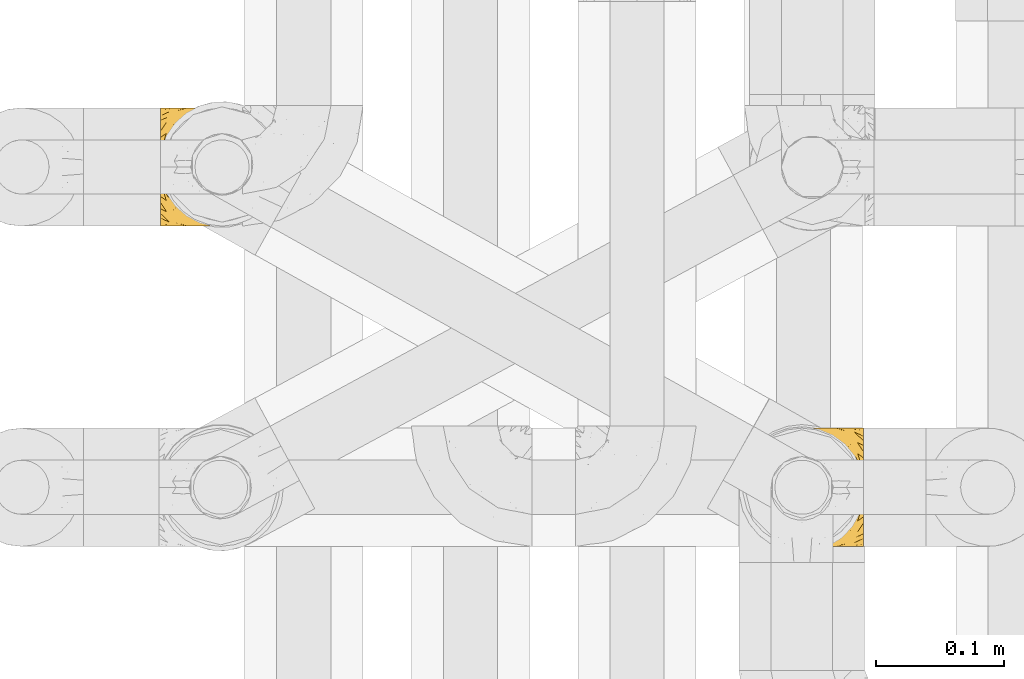
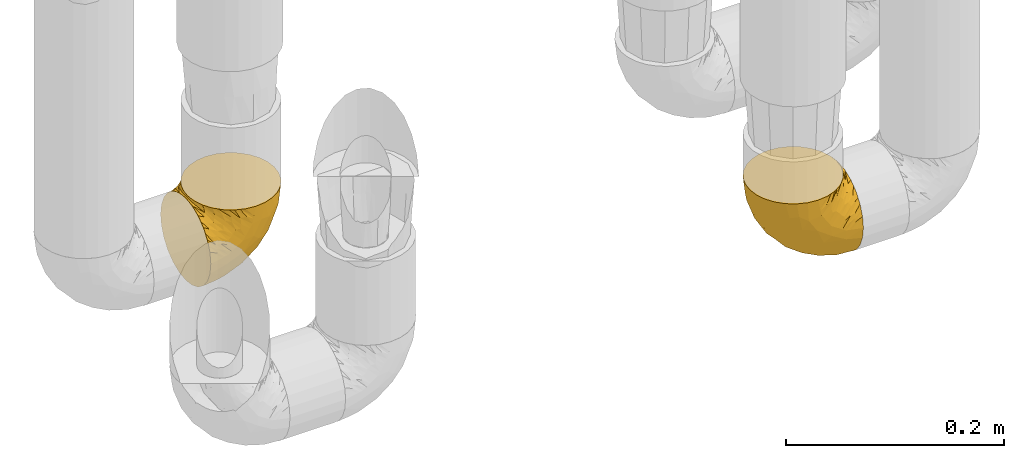
# One storey, part 162 of 827: 2 coverings.
"""IFC2X3 building model written with IfcOpenShell, lengths in millimetres."""

from ifc_helpers import new_model, entity, si_unit, converted_unit, derived_unit, direction, frame, origin, place, context, subcontext, project, spatial, faceted_brep, element, save


model = new_model("IFC2X3")

# Units and contexts
model_context = context("Model", 3, precision=0.01, world=origin(), true_north=direction((6.12303176911189e-17, 1.0)))
body_context = subcontext(model_context, "Body", "Model", "MODEL_VIEW")
ifc_project = project(units=[si_unit("LENGTHUNIT", "METRE", prefix="MILLI"), si_unit("AREAUNIT", "SQUARE_METRE"), si_unit("VOLUMEUNIT", "CUBIC_METRE"), converted_unit("PLANEANGLEUNIT", "DEGREE", entity("IfcRatioMeasure", 0.0174532925199433), si_unit("PLANEANGLEUNIT", "RADIAN"), dimensions=[0, 0, 0, 0, 0, 0, 0]), si_unit("MASSUNIT", "GRAM", prefix="KILO"), derived_unit("MASSDENSITYUNIT", [(si_unit("MASSUNIT", "GRAM", prefix="KILO"), 1), (si_unit("LENGTHUNIT", "METRE"), -3)]), derived_unit("MOMENTOFINERTIAUNIT", [(si_unit("LENGTHUNIT", "METRE"), 4)]), si_unit("TIMEUNIT", "SECOND"), si_unit("FREQUENCYUNIT", "HERTZ"), si_unit("THERMODYNAMICTEMPERATUREUNIT", "DEGREE_CELSIUS"), derived_unit("THERMALTRANSMITTANCEUNIT", [(si_unit("MASSUNIT", "GRAM", prefix="KILO"), 1), (si_unit("THERMODYNAMICTEMPERATUREUNIT", "KELVIN"), -1), (si_unit("TIMEUNIT", "SECOND"), -3)]), derived_unit("VOLUMETRICFLOWRATEUNIT", [(si_unit("LENGTHUNIT", "METRE"), 3), (si_unit("TIMEUNIT", "SECOND"), -1)]), derived_unit("MASSFLOWRATEUNIT", [(si_unit("MASSUNIT", "GRAM", prefix="KILO"), 1), (si_unit("TIMEUNIT", "SECOND"), -1)]), derived_unit("ROTATIONALFREQUENCYUNIT", [(si_unit("TIMEUNIT", "SECOND"), -1)]), si_unit("ELECTRICCURRENTUNIT", "AMPERE"), si_unit("ELECTRICVOLTAGEUNIT", "VOLT"), si_unit("POWERUNIT", "WATT"), si_unit("FORCEUNIT", "NEWTON", prefix="KILO"), si_unit("ILLUMINANCEUNIT", "LUX"), si_unit("LUMINOUSFLUXUNIT", "LUMEN"), si_unit("LUMINOUSINTENSITYUNIT", "CANDELA"), derived_unit("USERDEFINED", [(si_unit("MASSUNIT", "GRAM", prefix="KILO"), -1), (si_unit("LENGTHUNIT", "METRE"), -2), (si_unit("TIMEUNIT", "SECOND"), 3), (si_unit("LUMINOUSFLUXUNIT", "LUMEN"), 1)]), derived_unit("LINEARVELOCITYUNIT", [(si_unit("LENGTHUNIT", "METRE"), 1), (si_unit("TIMEUNIT", "SECOND"), -1)]), si_unit("PRESSUREUNIT", "PASCAL"), derived_unit("USERDEFINED", [(si_unit("LENGTHUNIT", "METRE"), -2), (si_unit("MASSUNIT", "GRAM", prefix="KILO"), 1), (si_unit("TIMEUNIT", "SECOND"), -2)]), derived_unit("LINEARFORCEUNIT", [(si_unit("MASSUNIT", "GRAM", prefix="KILO"), 1), (si_unit("LENGTHUNIT", "METRE"), 1), (si_unit("TIMEUNIT", "SECOND"), -2), (si_unit("LENGTHUNIT", "METRE"), -1)]), derived_unit("PLANARFORCEUNIT", [(si_unit("MASSUNIT", "GRAM", prefix="KILO"), 1), (si_unit("LENGTHUNIT", "METRE"), 1), (si_unit("TIMEUNIT", "SECOND"), -2), (si_unit("LENGTHUNIT", "METRE"), -2)])], contexts=[model_context])

# Site, building, storey
site_placement = place(None, origin())
site = spatial("IfcSite", under=ifc_project, at=site_placement, CompositionType="ELEMENT")
building_placement = place(site_placement, origin())
building = spatial("IfcBuilding", under=site, at=building_placement, CompositionType="ELEMENT")
storey_placement = place(building_placement, frame((0.0, 0.0, 28200.0)))
storey = spatial("IfcBuildingStorey", under=building, at=storey_placement, Name="08", CompositionType="ELEMENT", Elevation=28200.0)

# Coverings
covering_1_placement = place(storey_placement, frame((35226.64, 11758.41, 352.2)))
element("IfcCovering", 1, at=covering_1_placement, inside=storey, Name=":ADSK_", ObjectType=":ADSK_", PredefinedType="INSULATION", context=body_context, shape_type="Brep", body=[
    faceted_brep([(78.41, 11.68, 95.8), (85.72, 19.0, 95.8), (91.22, 27.76, 95.8), (94.64, 37.52, 95.8), (95.8, 47.8, 95.8), (94.64, 58.08, 95.8), (91.22, 67.85, 95.8), (85.71, 76.61, 95.8), (78.39, 83.92, 95.8), (69.63, 89.42, 95.8), (59.87, 92.84, 95.8), (49.6, 94.0, 95.8), (45.45, 93.53, 95.8), (42.38, 93.18, 95.8), (39.31, 92.84, 95.8), (34.43, 91.13, 95.8), (29.54, 89.42, 95.8), (25.16, 86.66, 95.8), (20.78, 83.91, 95.8), (17.13, 80.25, 95.8), (13.47, 76.59, 95.8), (7.97, 67.83, 95.8), (6.26, 62.95, 95.8), (4.55, 58.07, 95.8), (3.4, 47.8, 95.8), (4.55, 37.51, 95.8), (6.26, 32.63, 95.8), (7.97, 27.74, 95.8), (13.48, 18.98, 95.8), (17.14, 15.33, 95.8), (20.8, 11.67, 95.8), (25.18, 8.92, 95.8), (29.56, 6.17, 95.8), (34.44, 4.46, 95.8), (39.32, 2.75, 95.8), (42.39, 2.41, 95.8), (45.45, 2.06, 95.8), (49.6, 1.6, 95.8), (59.88, 2.75, 95.8), (69.65, 6.17, 95.8), (1.6, 47.8, 94.0), (1.6, 59.75, 92.42), (1.6, 70.9, 87.81), (1.6, 75.68, 84.13), (1.6, 80.46, 80.46), (1.6, 84.13, 75.68), (1.6, 87.81, 70.9), (1.6, 90.11, 65.32), (1.6, 92.42, 59.75), (1.6, 92.9, 56.14), (1.6, 93.17, 54.06), (1.6, 93.45, 51.97), (1.6, 94.0, 47.8), (1.6, 92.42, 35.84), (1.6, 87.81, 24.7), (1.6, 80.46, 15.13), (1.6, 70.9, 7.78), (1.6, 59.75, 3.17), (1.6, 47.8, 1.6), (1.6, 35.84, 3.17), (1.6, 24.7, 7.78), (1.6, 15.13, 15.13), (1.6, 7.78, 24.7), (1.6, 3.17, 35.84), (1.6, 1.6, 47.8), (1.6, 2.14, 51.97), (1.6, 2.69, 56.14), (1.6, 3.17, 59.75), (1.6, 5.48, 65.32), (1.6, 7.78, 70.9), (1.6, 11.46, 75.68), (1.6, 15.13, 80.46), (1.6, 19.91, 84.13), (1.6, 24.7, 87.81), (1.6, 35.84, 92.42), (36.81, 23.61, 15.84), (23.28, 31.99, 6.99), (45.8, 35.87, 14.39), (30.7, 47.8, 6.21), (21.2, 40.43, 4.26), (12.96, 47.8, 3.39), (66.19, 31.83, 31.2), (54.51, 23.37, 26.47), (17.98, 21.41, 11.44), (36.69, 3.07, 47.66), (35.54, 1.6, 61.85), (31.64, 1.6, 59.25), (27.75, 1.6, 56.65), (23.86, 1.6, 54.05), (19.96, 1.6, 51.45), (22.8, 13.45, 19.8), (42.67, 15.25, 26.22), (33.21, 8.07, 31.58), (59.45, 16.0, 38.36), (71.5, 17.34, 51.54), (62.66, 10.58, 51.6), (54.5, 5.34, 55.97), (47.57, 2.39, 62.88), (48.81, 8.36, 41.35), (74.98, 10.04, 82.24), (18.7, 2.59, 40.88), (15.75, 6.28, 29.0), (91.17, 34.28, 74.06), (85.28, 38.73, 54.53), (82.58, 27.25, 57.98), (75.78, 29.88, 43.81), (74.98, 38.6, 38.22), (67.27, 23.44, 38.33), (87.38, 25.25, 74.76), (82.04, 17.23, 76.85), (94.0, 47.8, 84.43), (77.8, 47.8, 40.43), (67.38, 47.8, 30.01), (56.2, 2.53, 78.67), (48.85, 1.6, 92.06), (48.11, 1.6, 88.32), (47.57, 1.6, 85.6), (47.03, 1.6, 82.88), (46.48, 1.6, 80.15), (45.94, 1.6, 77.43), (65.78, 5.71, 76.36), (17.24, 1.6, 50.91), (14.51, 1.6, 50.37), (11.79, 1.6, 49.82), (9.07, 1.6, 49.28), (7.2, 1.6, 48.91), (5.33, 1.6, 48.54), (91.18, 47.8, 66.69), (43.34, 1.6, 73.53), (40.74, 1.6, 69.64), (38.14, 1.6, 65.75), (72.73, 11.89, 66.13), (56.96, 47.8, 19.59), (62.23, 39.69, 24.64), (84.49, 47.8, 53.56), (43.83, 47.8, 12.9), (12.05, 13.84, 82.81), (18.95, 9.16, 81.22), (13.02, 15.79, 86.57), (8.34, 25.75, 92.75), (14.63, 16.09, 89.68), (11.09, 7.51, 72.26), (13.66, 3.99, 64.73), (20.08, 2.66, 62.45), (9.61, 3.16, 60.63), (9.48, 2.35, 56.91), (16.1, 2.23, 58.14), (3.42, 38.35, 93.7), (26.63, 6.18, 83.4), (33.72, 2.7, 75.54), (34.77, 2.93, 79.46), (6.75, 16.01, 82.28), (13.31, 9.08, 76.25), (21.11, 9.3, 84.69), (19.94, 11.68, 90.18), (8.67, 4.65, 65.12), (26.11, 3.65, 71.71), (29.3, 3.61, 75.21), (6.32, 12.8, 78.6), (39.92, 2.43, 87.27), (27.05, 6.83, 87.92), (6.04, 21.65, 86.94), (34.4, 3.7, 86.1), (2.87, 47.8, 94.52), (20.92, 3.37, 66.23), (27.43, 7.03, 91.08), (7.54, 7.87, 71.77), (18.45, 7.26, 76.21), (23.88, 3.41, 68.59), (7.77, 23.81, 89.94), (13.3, 86.5, 76.25), (11.09, 88.08, 72.26), (6.33, 82.79, 78.6), (9.07, 94.0, 49.28), (5.33, 94.0, 48.54), (14.51, 94.0, 50.37), (11.79, 94.0, 49.82), (3.42, 57.24, 93.7), (7.76, 71.76, 89.95), (47.03, 94.0, 82.88), (47.57, 94.0, 85.6), (48.85, 94.0, 92.06), (48.11, 94.0, 88.32), (14.62, 79.49, 89.68), (27.03, 88.75, 87.92), (20.08, 92.93, 62.45), (20.92, 92.22, 66.24), (27.75, 94.0, 56.65), (31.64, 94.0, 59.25), (9.61, 92.43, 60.63), (9.48, 93.24, 56.91), (8.33, 69.82, 92.76), (6.74, 79.57, 82.28), (12.04, 81.74, 82.81), (23.86, 94.0, 54.05), (19.96, 94.0, 51.45), (16.1, 93.36, 58.14), (19.93, 83.9, 90.18), (21.1, 86.28, 84.7), (39.92, 93.16, 87.25), (33.68, 92.88, 75.58), (29.28, 91.98, 75.2), (26.62, 89.41, 83.39), (26.08, 91.93, 71.7), (18.93, 86.42, 81.22), (27.87, 88.82, 90.73), (34.75, 92.66, 79.47), (6.04, 73.93, 86.94), (38.14, 94.0, 65.75), (12.79, 79.5, 86.75), (34.41, 91.89, 86.08), (45.94, 94.0, 77.43), (43.34, 94.0, 73.53), (40.74, 94.0, 69.64), (13.66, 91.6, 64.73), (17.24, 94.0, 50.91), (8.67, 90.94, 65.12), (35.54, 94.0, 61.85), (23.83, 92.16, 68.62), (18.43, 88.32, 76.22), (6.03, 86.13, 74.03), (46.48, 94.0, 80.15), (34.52, 93.2, 49.81), (21.2, 55.16, 4.26), (23.82, 82.02, 19.95), (41.32, 84.29, 30.61), (47.62, 76.94, 25.71), (52.66, 68.33, 22.43), (36.81, 71.98, 15.85), (49.75, 92.52, 60.69), (19.07, 92.9, 40.49), (45.8, 59.72, 14.39), (23.28, 63.6, 6.99), (21.35, 88.89, 29.56), (17.98, 74.18, 11.45), (82.57, 68.35, 57.98), (91.17, 61.33, 74.06), (85.27, 56.86, 54.52), (73.89, 68.62, 43.47), (66.19, 63.76, 31.2), (62.43, 72.19, 33.27), (63.53, 88.69, 64.26), (58.45, 92.19, 74.29), (67.16, 89.75, 80.41), (62.22, 55.9, 24.64), (81.54, 77.99, 73.62), (74.8, 85.21, 78.98), (75.83, 74.99, 53.69), (41.45, 90.23, 42.86), (76.72, 59.86, 41.67), (88.2, 70.75, 79.66), (71.6, 81.72, 58.41), (56.23, 86.53, 47.11), (59.44, 79.6, 38.37)], [[[0, 1, 2, 3, 4, 5, 6, 7, 8, 9, 10, 11, 12, 13, 14, 15, 16, 17, 18, 19, 20, 21, 22, 23, 24, 25, 26, 27, 28, 29, 30, 31, 32, 33, 34, 35, 36, 37, 38, 39]], [[40, 41, 42, 43, 44, 45, 46, 47, 48, 49, 50, 51, 52, 53, 54, 55, 56, 57, 58, 59, 60, 61, 62, 63, 64, 65, 66, 67, 68, 69, 70, 71, 72, 73, 74]], [[75, 76, 77]], [[78, 79, 80]], [[77, 81, 82]], [[76, 75, 83]], [[84, 85, 86, 87, 88, 89]], [[90, 91, 92]], [[76, 60, 59]], [[93, 94, 95]], [[90, 62, 61]], [[83, 61, 60]], [[96, 97, 84]], [[98, 93, 95]], [[0, 39, 99]], [[100, 84, 89]], [[62, 101, 63]], [[2, 102, 3]], [[92, 84, 100]], [[103, 102, 104]], [[103, 105, 106]], [[93, 107, 94]], [[1, 108, 2]], [[92, 101, 90]], [[108, 1, 109]], [[102, 110, 3]], [[93, 82, 107]], [[102, 108, 104]], [[111, 106, 112]], [[109, 0, 99]], [[113, 37, 114, 115, 116, 117, 118, 119]], [[120, 38, 113]], [[100, 89, 121, 122, 123, 124, 125, 126, 64]], [[127, 102, 103]], [[97, 119, 128, 129, 130, 85]], [[99, 120, 131]], [[132, 133, 77]], [[59, 80, 79]], [[1, 0, 109]], [[98, 84, 92]], [[94, 109, 131]], [[120, 39, 38]], [[93, 91, 82]], [[104, 94, 105]], [[97, 113, 119]], [[95, 120, 96]], [[83, 90, 61]], [[91, 93, 98]], [[64, 63, 100]], [[100, 63, 101]], [[77, 76, 79]], [[133, 106, 81]], [[84, 97, 85]], [[113, 96, 120]], [[113, 97, 96]], [[37, 113, 38]], [[110, 102, 127]], [[110, 4, 3]], [[103, 111, 134, 127]], [[90, 75, 91]], [[82, 81, 107]], [[91, 75, 82]], [[77, 82, 75]], [[76, 83, 60]], [[90, 83, 75]], [[105, 107, 81]], [[94, 131, 95]], [[105, 94, 107]], [[109, 94, 104]], [[120, 95, 131]], [[98, 95, 96]], [[84, 98, 96]], [[98, 92, 91]], [[106, 105, 81]], [[103, 104, 105]], [[112, 106, 133]], [[103, 106, 111]], [[112, 133, 132]], [[81, 77, 133]], [[77, 78, 135, 132]], [[120, 99, 39]], [[109, 99, 131]], [[59, 58, 80]], [[59, 79, 76]], [[90, 101, 62]], [[100, 101, 92]], [[2, 108, 102]], [[109, 104, 108]], [[78, 77, 79]], [[136, 137, 138]], [[27, 139, 140]], [[141, 142, 143]], [[144, 145, 121]], [[146, 89, 88]], [[147, 139, 25]], [[148, 149, 150]], [[136, 151, 152]], [[147, 40, 74]], [[24, 147, 25]], [[140, 153, 154]], [[33, 116, 34]], [[73, 72, 151]], [[114, 37, 36, 35, 34, 116, 115]], [[146, 155, 144]], [[156, 85, 130]], [[157, 149, 148]], [[151, 158, 152]], [[117, 33, 159]], [[29, 154, 160]], [[161, 74, 73]], [[162, 128, 119]], [[66, 65, 64, 126, 125, 124, 123, 122, 67]], [[163, 147, 24]], [[27, 140, 28]], [[149, 129, 150]], [[139, 27, 26, 25]], [[68, 144, 69]], [[129, 128, 150]], [[164, 87, 86]], [[130, 129, 149]], [[122, 145, 67]], [[154, 153, 148]], [[162, 119, 159]], [[165, 30, 160]], [[150, 160, 148]], [[128, 162, 150]], [[30, 165, 31]], [[145, 144, 68]], [[89, 146, 144]], [[87, 164, 143]], [[166, 155, 142]], [[88, 87, 143]], [[162, 160, 150]], [[160, 30, 29]], [[154, 29, 28]], [[140, 154, 28]], [[160, 154, 148]], [[140, 137, 153]], [[157, 148, 153]], [[156, 130, 157]], [[153, 137, 157]], [[157, 137, 156]], [[167, 137, 136]], [[168, 85, 156]], [[152, 168, 167]], [[167, 168, 156]], [[164, 152, 141]], [[71, 158, 72]], [[152, 167, 136]], [[88, 142, 146]], [[144, 155, 69]], [[146, 142, 155]], [[70, 166, 71]], [[142, 141, 166]], [[70, 69, 155]], [[141, 158, 71]], [[161, 73, 151]], [[138, 137, 140]], [[161, 136, 169]], [[136, 161, 151]], [[74, 161, 169]], [[152, 158, 141]], [[151, 72, 158]], [[168, 152, 164]], [[137, 167, 156]], [[164, 86, 168]], [[85, 168, 86]], [[116, 33, 117]], [[130, 149, 157]], [[67, 145, 68]], [[121, 89, 144]], [[145, 122, 121]], [[40, 147, 163]], [[169, 147, 74]], [[159, 33, 32]], [[162, 159, 32]], [[159, 119, 118, 117]], [[139, 147, 169]], [[139, 169, 138]], [[162, 32, 31]], [[141, 143, 164]], [[88, 143, 142]], [[71, 166, 141]], [[155, 166, 70]], [[139, 138, 140]], [[169, 136, 138]], [[160, 162, 165]], [[162, 31, 165]], [[170, 171, 172]], [[173, 174, 52, 51, 50, 49, 48, 175, 176]], [[177, 178, 41]], [[179, 15, 180]], [[12, 11, 181, 182, 180, 14, 13]], [[183, 21, 20]], [[19, 18, 184]], [[185, 186, 187]], [[186, 188, 187]], [[43, 172, 44]], [[189, 190, 47]], [[23, 22, 21, 191]], [[170, 192, 193]], [[40, 163, 177]], [[194, 195, 196]], [[24, 23, 177]], [[197, 198, 183]], [[199, 15, 179]], [[47, 46, 189]], [[200, 201, 202]], [[201, 203, 204]], [[205, 206, 184]], [[207, 41, 178]], [[16, 15, 199]], [[14, 180, 15]], [[202, 201, 198]], [[208, 201, 200]], [[163, 24, 177]], [[48, 47, 190]], [[196, 195, 189]], [[197, 184, 202]], [[204, 193, 209]], [[210, 211, 212]], [[206, 212, 213]], [[205, 17, 210]], [[184, 206, 202]], [[210, 212, 206]], [[185, 194, 214]], [[189, 215, 190]], [[216, 45, 214]], [[186, 171, 170]], [[189, 216, 196]], [[197, 20, 19]], [[194, 185, 187]], [[197, 183, 20]], [[184, 197, 19]], [[197, 202, 198]], [[206, 200, 202]], [[204, 183, 198]], [[201, 208, 203]], [[203, 208, 217]], [[204, 198, 201]], [[217, 188, 218]], [[193, 219, 170]], [[171, 186, 185]], [[170, 218, 186]], [[170, 219, 218]], [[42, 207, 192]], [[171, 220, 172]], [[216, 189, 46]], [[214, 194, 196]], [[44, 220, 45]], [[214, 196, 216]], [[216, 46, 45]], [[214, 45, 220]], [[192, 43, 42]], [[204, 203, 219]], [[207, 193, 192]], [[209, 193, 178]], [[41, 207, 42]], [[193, 207, 178]], [[43, 192, 172]], [[170, 172, 192]], [[204, 219, 193]], [[219, 203, 218]], [[217, 218, 203]], [[188, 186, 218]], [[206, 213, 200]], [[208, 200, 213]], [[199, 210, 16]], [[215, 189, 195]], [[215, 175, 190]], [[175, 48, 190]], [[199, 179, 221, 211]], [[210, 199, 211]], [[23, 191, 177]], [[40, 177, 41]], [[178, 177, 191]], [[21, 183, 191]], [[209, 191, 183]], [[205, 18, 17]], [[17, 16, 210]], [[171, 185, 214]], [[172, 220, 44]], [[214, 220, 171]], [[191, 209, 178]], [[204, 209, 183]], [[206, 205, 210]], [[18, 205, 184]], [[222, 195, 194, 187, 188, 217]], [[57, 223, 80]], [[224, 225, 226]], [[226, 227, 228]], [[229, 217, 208, 213, 212, 211]], [[230, 52, 174, 173, 176, 175, 215, 195]], [[231, 232, 228]], [[231, 78, 223]], [[223, 57, 232]], [[224, 233, 225]], [[233, 54, 53]], [[234, 232, 56]], [[56, 55, 234]], [[234, 224, 228]], [[235, 236, 237]], [[224, 55, 54]], [[238, 239, 240]], [[52, 230, 53]], [[241, 242, 243]], [[227, 244, 231]], [[11, 10, 242]], [[236, 6, 5]], [[7, 245, 8]], [[8, 246, 9]], [[238, 247, 235]], [[222, 229, 248]], [[242, 211, 221, 179, 180, 182, 181, 11]], [[233, 53, 230]], [[111, 112, 249]], [[250, 6, 236]], [[246, 251, 241]], [[6, 250, 7]], [[127, 236, 110]], [[248, 229, 252]], [[246, 8, 245]], [[235, 245, 250]], [[236, 5, 110]], [[235, 249, 238]], [[237, 236, 127]], [[243, 9, 246]], [[252, 229, 241]], [[56, 232, 57]], [[222, 230, 195]], [[225, 248, 252]], [[248, 233, 230]], [[54, 233, 224]], [[231, 228, 227]], [[244, 132, 231]], [[248, 225, 233]], [[226, 225, 253]], [[235, 250, 236]], [[245, 7, 250]], [[251, 246, 245]], [[243, 246, 241]], [[247, 245, 235]], [[252, 251, 253]], [[229, 222, 217]], [[230, 222, 248]], [[5, 4, 110]], [[237, 127, 134, 111]], [[238, 249, 239]], [[224, 234, 55]], [[232, 234, 228]], [[242, 241, 229]], [[10, 9, 243]], [[211, 242, 229]], [[10, 243, 242]], [[80, 223, 78]], [[80, 58, 57]], [[231, 223, 232]], [[227, 240, 239]], [[224, 226, 228]], [[240, 226, 253]], [[227, 239, 244]], [[226, 240, 227]], [[251, 247, 253]], [[240, 253, 247]], [[249, 235, 237]], [[237, 111, 249]], [[112, 132, 244]], [[112, 244, 249]], [[78, 231, 132, 135]], [[249, 244, 239]], [[247, 238, 240]], [[245, 247, 251]], [[251, 252, 241]], [[225, 252, 253]]]),
])
covering_2_placement = place(storey_placement, frame((35680.99, 11508.37, 352.2)))
element("IfcCovering", 2, at=covering_2_placement, inside=storey, Name=":ADSK_", ObjectType=":ADSK_", PredefinedType="INSULATION", context=body_context, shape_type="Brep", body=[
    faceted_brep([(18.98, 83.91, 95.8), (11.67, 76.59, 95.8), (6.17, 67.83, 95.8), (2.75, 58.07, 95.8), (1.6, 47.8, 95.8), (2.75, 37.51, 95.8), (6.17, 27.74, 95.8), (11.68, 18.98, 95.8), (19.0, 11.67, 95.8), (27.76, 6.17, 95.8), (37.52, 2.75, 95.8), (47.8, 1.6, 95.8), (51.94, 2.06, 95.8), (55.01, 2.41, 95.8), (58.08, 2.75, 95.8), (62.96, 4.46, 95.8), (67.85, 6.17, 95.8), (72.23, 8.93, 95.8), (76.61, 11.68, 95.8), (80.26, 15.34, 95.8), (83.92, 19.0, 95.8), (89.42, 27.76, 95.8), (91.13, 32.64, 95.8), (92.84, 37.52, 95.8), (94.0, 47.8, 95.8), (92.84, 58.08, 95.8), (91.13, 62.96, 95.8), (89.42, 67.85, 95.8), (83.91, 76.61, 95.8), (80.25, 80.26, 95.8), (76.59, 83.92, 95.8), (72.21, 86.67, 95.8), (67.83, 89.42, 95.8), (62.95, 91.13, 95.8), (58.07, 92.84, 95.8), (55.0, 93.18, 95.8), (51.94, 93.53, 95.8), (47.8, 94.0, 95.8), (37.51, 92.84, 95.8), (27.74, 89.42, 95.8), (95.8, 47.8, 94.0), (95.8, 35.84, 92.42), (95.8, 24.7, 87.81), (95.8, 19.91, 84.13), (95.8, 15.13, 80.46), (95.8, 11.46, 75.68), (95.8, 7.78, 70.9), (95.8, 5.48, 65.32), (95.8, 3.17, 59.75), (95.8, 2.69, 56.14), (95.8, 2.42, 54.06), (95.8, 2.14, 51.97), (95.8, 1.6, 47.8), (95.8, 3.17, 35.84), (95.8, 7.78, 24.7), (95.8, 15.13, 15.13), (95.8, 24.7, 7.78), (95.8, 35.84, 3.17), (95.8, 47.8, 1.6), (95.8, 59.75, 3.17), (95.8, 70.9, 7.78), (95.8, 80.46, 15.13), (95.8, 87.81, 24.7), (95.8, 92.42, 35.84), (95.8, 94.0, 47.8), (95.8, 93.45, 51.97), (95.8, 92.9, 56.14), (95.8, 92.42, 59.75), (95.8, 90.11, 65.32), (95.8, 87.81, 70.9), (95.8, 84.13, 75.68), (95.8, 80.46, 80.46), (95.8, 75.68, 84.13), (95.8, 70.9, 87.81), (95.8, 59.75, 92.42), (60.58, 71.98, 15.84), (74.11, 63.6, 6.99), (51.59, 59.72, 14.39), (66.69, 47.8, 6.21), (76.19, 55.16, 4.26), (84.43, 47.8, 3.39), (31.2, 63.76, 31.2), (42.88, 72.22, 26.47), (79.41, 74.18, 11.44), (60.7, 92.52, 47.66), (61.85, 94.0, 61.85), (65.75, 94.0, 59.25), (69.64, 94.0, 56.65), (73.53, 94.0, 54.05), (77.43, 94.0, 51.45), (74.59, 82.14, 19.8), (54.72, 80.34, 26.22), (64.18, 87.52, 31.58), (37.94, 79.59, 38.36), (25.89, 78.25, 51.54), (34.73, 85.01, 51.6), (42.89, 90.25, 55.97), (49.83, 93.2, 62.88), (48.58, 87.23, 41.35), (22.41, 85.55, 82.24), (78.69, 93.0, 40.88), (81.64, 89.31, 29.0), (6.22, 61.31, 74.06), (12.11, 56.86, 54.53), (14.81, 68.34, 57.98), (21.61, 65.71, 43.81), (22.41, 56.99, 38.22), (30.12, 72.15, 38.33), (10.01, 70.34, 74.76), (15.36, 78.36, 76.85), (3.39, 47.8, 84.43), (19.59, 47.8, 40.43), (30.01, 47.8, 30.01), (41.19, 93.06, 78.67), (48.54, 94.0, 92.06), (49.28, 94.0, 88.32), (49.82, 94.0, 85.6), (50.37, 94.0, 82.88), (50.91, 94.0, 80.15), (51.45, 94.0, 77.43), (31.61, 89.88, 76.36), (80.15, 94.0, 50.91), (82.88, 94.0, 50.37), (85.6, 94.0, 49.82), (88.32, 94.0, 49.28), (90.19, 94.0, 48.91), (92.06, 94.0, 48.54), (6.21, 47.8, 66.69), (54.05, 94.0, 73.53), (56.65, 94.0, 69.64), (59.25, 94.0, 65.75), (24.66, 83.7, 66.13), (40.43, 47.8, 19.59), (35.17, 55.9, 24.64), (12.9, 47.8, 53.56), (53.56, 47.8, 12.9), (85.34, 81.75, 82.81), (78.44, 86.43, 81.22), (84.37, 79.8, 86.57), (89.05, 69.84, 92.75), (82.76, 79.5, 89.68), (86.31, 88.08, 72.26), (83.73, 91.6, 64.73), (77.31, 92.93, 62.45), (87.78, 92.43, 60.63), (87.91, 93.24, 56.91), (81.29, 93.36, 58.14), (93.97, 57.25, 93.7), (70.76, 89.41, 83.4), (63.67, 92.89, 75.54), (62.62, 92.66, 79.46), (90.64, 79.58, 82.28), (84.08, 86.51, 76.25), (76.28, 86.29, 84.69), (77.45, 83.91, 90.18), (88.72, 90.94, 65.12), (71.28, 91.94, 71.71), (68.09, 91.98, 75.21), (91.07, 82.79, 78.6), (57.47, 93.16, 87.27), (70.34, 88.76, 87.92), (91.35, 73.94, 86.94), (62.99, 91.89, 86.1), (94.52, 47.8, 94.52), (76.47, 92.22, 66.23), (69.96, 88.56, 91.08), (89.86, 87.72, 71.77), (78.94, 88.33, 76.21), (73.51, 92.18, 68.59), (89.62, 71.78, 89.94), (84.09, 9.09, 76.25), (86.3, 7.51, 72.26), (91.06, 12.8, 78.6), (88.32, 1.6, 49.28), (92.06, 1.6, 48.54), (82.88, 1.6, 50.37), (85.6, 1.6, 49.82), (93.97, 38.35, 93.7), (89.63, 23.84, 89.95), (50.37, 1.6, 82.88), (49.82, 1.6, 85.6), (48.54, 1.6, 92.06), (49.28, 1.6, 88.32), (82.77, 16.1, 89.68), (70.36, 6.84, 87.92), (77.31, 2.66, 62.45), (76.47, 3.37, 66.24), (69.64, 1.6, 56.65), (65.75, 1.6, 59.25), (87.78, 3.16, 60.63), (87.91, 2.35, 56.91), (89.06, 25.77, 92.76), (90.65, 16.02, 82.28), (85.35, 13.85, 82.81), (73.53, 1.6, 54.05), (77.43, 1.6, 51.45), (81.29, 2.23, 58.14), (77.46, 11.69, 90.18), (76.29, 9.31, 84.7), (57.47, 2.43, 87.25), (63.71, 2.71, 75.58), (68.11, 3.61, 75.2), (70.77, 6.18, 83.39), (71.31, 3.66, 71.7), (78.46, 9.17, 81.22), (69.52, 6.77, 90.73), (62.64, 2.93, 79.47), (91.35, 21.66, 86.94), (59.25, 1.6, 65.75), (84.6, 16.09, 86.75), (62.98, 3.7, 86.08), (51.45, 1.6, 77.43), (54.05, 1.6, 73.53), (56.65, 1.6, 69.64), (83.73, 3.99, 64.73), (80.15, 1.6, 50.91), (88.72, 4.65, 65.12), (61.85, 1.6, 61.85), (73.56, 3.43, 68.62), (78.96, 7.27, 76.22), (91.36, 9.46, 74.03), (50.91, 1.6, 80.15), (62.87, 2.4, 49.81), (76.19, 40.43, 4.26), (73.57, 13.57, 19.95), (56.07, 11.3, 30.61), (49.77, 18.65, 25.71), (44.73, 27.26, 22.43), (60.58, 23.61, 15.85), (47.64, 3.07, 60.69), (78.32, 2.69, 40.49), (51.59, 35.87, 14.39), (74.11, 31.99, 6.99), (76.04, 6.71, 29.56), (79.41, 21.41, 11.45), (14.82, 27.24, 57.98), (6.22, 34.26, 74.06), (12.12, 38.73, 54.52), (23.51, 26.97, 43.47), (31.2, 31.83, 31.2), (34.96, 23.4, 33.27), (33.86, 6.91, 64.26), (38.94, 3.4, 74.29), (30.23, 5.84, 80.41), (35.17, 39.69, 24.64), (15.85, 17.6, 73.62), (22.59, 10.38, 78.98), (21.56, 20.6, 53.69), (55.94, 5.36, 42.86), (20.67, 35.73, 41.67), (9.19, 24.84, 79.66), (25.79, 13.87, 58.41), (41.16, 9.06, 47.11), (37.95, 15.99, 38.37)], [[[0, 1, 2, 3, 4, 5, 6, 7, 8, 9, 10, 11, 12, 13, 14, 15, 16, 17, 18, 19, 20, 21, 22, 23, 24, 25, 26, 27, 28, 29, 30, 31, 32, 33, 34, 35, 36, 37, 38, 39]], [[40, 41, 42, 43, 44, 45, 46, 47, 48, 49, 50, 51, 52, 53, 54, 55, 56, 57, 58, 59, 60, 61, 62, 63, 64, 65, 66, 67, 68, 69, 70, 71, 72, 73, 74]], [[75, 76, 77]], [[78, 79, 80]], [[77, 81, 82]], [[76, 75, 83]], [[84, 85, 86, 87, 88, 89]], [[90, 91, 92]], [[76, 60, 59]], [[93, 94, 95]], [[90, 62, 61]], [[83, 61, 60]], [[96, 97, 84]], [[98, 93, 95]], [[0, 39, 99]], [[100, 84, 89]], [[62, 101, 63]], [[2, 102, 3]], [[92, 84, 100]], [[103, 102, 104]], [[103, 105, 106]], [[93, 107, 94]], [[1, 108, 2]], [[92, 101, 90]], [[108, 1, 109]], [[102, 110, 3]], [[93, 82, 107]], [[102, 108, 104]], [[111, 106, 112]], [[109, 0, 99]], [[113, 37, 114, 115, 116, 117, 118, 119]], [[120, 38, 113]], [[100, 89, 121, 122, 123, 124, 125, 126, 64]], [[127, 102, 103]], [[97, 119, 128, 129, 130, 85]], [[99, 120, 131]], [[132, 133, 77]], [[59, 80, 79]], [[1, 0, 109]], [[98, 84, 92]], [[94, 109, 131]], [[120, 39, 38]], [[93, 91, 82]], [[104, 94, 105]], [[97, 113, 119]], [[95, 120, 96]], [[83, 90, 61]], [[91, 93, 98]], [[64, 63, 100]], [[100, 63, 101]], [[77, 76, 79]], [[133, 106, 81]], [[84, 97, 85]], [[113, 96, 120]], [[113, 97, 96]], [[37, 113, 38]], [[110, 102, 127]], [[110, 4, 3]], [[103, 111, 134, 127]], [[90, 75, 91]], [[82, 81, 107]], [[91, 75, 82]], [[77, 82, 75]], [[76, 83, 60]], [[90, 83, 75]], [[105, 107, 81]], [[94, 131, 95]], [[105, 94, 107]], [[109, 94, 104]], [[120, 95, 131]], [[98, 95, 96]], [[84, 98, 96]], [[98, 92, 91]], [[106, 105, 81]], [[103, 104, 105]], [[112, 106, 133]], [[103, 106, 111]], [[112, 133, 132]], [[81, 77, 133]], [[77, 78, 135, 132]], [[120, 99, 39]], [[109, 99, 131]], [[59, 58, 80]], [[59, 79, 76]], [[90, 101, 62]], [[100, 101, 92]], [[2, 108, 102]], [[109, 104, 108]], [[78, 77, 79]], [[136, 137, 138]], [[27, 139, 140]], [[141, 142, 143]], [[144, 145, 121]], [[146, 89, 88]], [[147, 139, 25]], [[148, 149, 150]], [[136, 151, 152]], [[147, 40, 74]], [[24, 147, 25]], [[140, 153, 154]], [[33, 116, 34]], [[73, 72, 151]], [[114, 37, 36, 35, 34, 116, 115]], [[146, 155, 144]], [[156, 85, 130]], [[157, 149, 148]], [[151, 158, 152]], [[117, 33, 159]], [[29, 154, 160]], [[161, 74, 73]], [[162, 128, 119]], [[66, 65, 64, 126, 125, 124, 123, 122, 67]], [[163, 147, 24]], [[27, 140, 28]], [[149, 129, 150]], [[139, 27, 26, 25]], [[68, 144, 69]], [[129, 128, 150]], [[164, 87, 86]], [[130, 129, 149]], [[122, 145, 67]], [[154, 153, 148]], [[162, 119, 159]], [[165, 30, 160]], [[150, 160, 148]], [[128, 162, 150]], [[30, 165, 31]], [[145, 144, 68]], [[89, 146, 144]], [[87, 164, 143]], [[166, 155, 142]], [[88, 87, 143]], [[162, 160, 150]], [[160, 30, 29]], [[154, 29, 28]], [[140, 154, 28]], [[160, 154, 148]], [[140, 137, 153]], [[157, 148, 153]], [[156, 130, 157]], [[153, 137, 157]], [[157, 137, 156]], [[167, 137, 136]], [[168, 85, 156]], [[152, 168, 167]], [[167, 168, 156]], [[164, 152, 141]], [[71, 158, 72]], [[152, 167, 136]], [[88, 142, 146]], [[144, 155, 69]], [[146, 142, 155]], [[70, 166, 71]], [[142, 141, 166]], [[70, 69, 155]], [[141, 158, 71]], [[161, 73, 151]], [[138, 137, 140]], [[161, 136, 169]], [[136, 161, 151]], [[74, 161, 169]], [[152, 158, 141]], [[151, 72, 158]], [[168, 152, 164]], [[137, 167, 156]], [[164, 86, 168]], [[85, 168, 86]], [[116, 33, 117]], [[130, 149, 157]], [[67, 145, 68]], [[121, 89, 144]], [[145, 122, 121]], [[40, 147, 163]], [[169, 147, 74]], [[159, 33, 32]], [[162, 159, 32]], [[159, 119, 118, 117]], [[139, 147, 169]], [[139, 169, 138]], [[162, 32, 31]], [[141, 143, 164]], [[88, 143, 142]], [[71, 166, 141]], [[155, 166, 70]], [[139, 138, 140]], [[169, 136, 138]], [[160, 162, 165]], [[162, 31, 165]], [[170, 171, 172]], [[173, 174, 52, 51, 50, 49, 48, 175, 176]], [[177, 178, 41]], [[179, 15, 180]], [[12, 11, 181, 182, 180, 14, 13]], [[183, 21, 20]], [[19, 18, 184]], [[185, 186, 187]], [[186, 188, 187]], [[43, 172, 44]], [[189, 190, 47]], [[23, 22, 21, 191]], [[170, 192, 193]], [[40, 163, 177]], [[194, 195, 196]], [[24, 23, 177]], [[197, 198, 183]], [[199, 15, 179]], [[47, 46, 189]], [[200, 201, 202]], [[201, 203, 204]], [[205, 206, 184]], [[207, 41, 178]], [[16, 15, 199]], [[14, 180, 15]], [[202, 201, 198]], [[208, 201, 200]], [[163, 24, 177]], [[48, 47, 190]], [[196, 195, 189]], [[197, 184, 202]], [[204, 193, 209]], [[210, 211, 212]], [[206, 212, 213]], [[205, 17, 210]], [[184, 206, 202]], [[210, 212, 206]], [[185, 194, 214]], [[189, 215, 190]], [[216, 45, 214]], [[186, 171, 170]], [[189, 216, 196]], [[197, 20, 19]], [[194, 185, 187]], [[197, 183, 20]], [[184, 197, 19]], [[197, 202, 198]], [[206, 200, 202]], [[204, 183, 198]], [[201, 208, 203]], [[203, 208, 217]], [[204, 198, 201]], [[217, 188, 218]], [[193, 219, 170]], [[171, 186, 185]], [[170, 218, 186]], [[170, 219, 218]], [[42, 207, 192]], [[171, 220, 172]], [[216, 189, 46]], [[214, 194, 196]], [[44, 220, 45]], [[214, 196, 216]], [[216, 46, 45]], [[214, 45, 220]], [[192, 43, 42]], [[204, 203, 219]], [[207, 193, 192]], [[209, 193, 178]], [[41, 207, 42]], [[193, 207, 178]], [[43, 192, 172]], [[170, 172, 192]], [[204, 219, 193]], [[219, 203, 218]], [[217, 218, 203]], [[188, 186, 218]], [[206, 213, 200]], [[208, 200, 213]], [[199, 210, 16]], [[215, 189, 195]], [[215, 175, 190]], [[175, 48, 190]], [[199, 179, 221, 211]], [[210, 199, 211]], [[23, 191, 177]], [[40, 177, 41]], [[178, 177, 191]], [[21, 183, 191]], [[209, 191, 183]], [[205, 18, 17]], [[17, 16, 210]], [[171, 185, 214]], [[172, 220, 44]], [[214, 220, 171]], [[191, 209, 178]], [[204, 209, 183]], [[206, 205, 210]], [[18, 205, 184]], [[222, 195, 194, 187, 188, 217]], [[57, 223, 80]], [[224, 225, 226]], [[226, 227, 228]], [[229, 217, 208, 213, 212, 211]], [[230, 52, 174, 173, 176, 175, 215, 195]], [[231, 232, 228]], [[231, 78, 223]], [[223, 57, 232]], [[224, 233, 225]], [[233, 54, 53]], [[234, 232, 56]], [[56, 55, 234]], [[234, 224, 228]], [[235, 236, 237]], [[224, 55, 54]], [[238, 239, 240]], [[52, 230, 53]], [[241, 242, 243]], [[227, 244, 231]], [[11, 10, 242]], [[236, 6, 5]], [[7, 245, 8]], [[8, 246, 9]], [[238, 247, 235]], [[222, 229, 248]], [[242, 211, 221, 179, 180, 182, 181, 11]], [[233, 53, 230]], [[111, 112, 249]], [[250, 6, 236]], [[246, 251, 241]], [[6, 250, 7]], [[127, 236, 110]], [[248, 229, 252]], [[246, 8, 245]], [[235, 245, 250]], [[236, 5, 110]], [[235, 249, 238]], [[237, 236, 127]], [[243, 9, 246]], [[252, 229, 241]], [[56, 232, 57]], [[222, 230, 195]], [[225, 248, 252]], [[248, 233, 230]], [[54, 233, 224]], [[231, 228, 227]], [[244, 132, 231]], [[248, 225, 233]], [[226, 225, 253]], [[235, 250, 236]], [[245, 7, 250]], [[251, 246, 245]], [[243, 246, 241]], [[247, 245, 235]], [[252, 251, 253]], [[229, 222, 217]], [[230, 222, 248]], [[5, 4, 110]], [[237, 127, 134, 111]], [[238, 249, 239]], [[224, 234, 55]], [[232, 234, 228]], [[242, 241, 229]], [[10, 9, 243]], [[211, 242, 229]], [[10, 243, 242]], [[80, 223, 78]], [[80, 58, 57]], [[231, 223, 232]], [[227, 240, 239]], [[224, 226, 228]], [[240, 226, 253]], [[227, 239, 244]], [[226, 240, 227]], [[251, 247, 253]], [[240, 253, 247]], [[249, 235, 237]], [[237, 111, 249]], [[112, 132, 244]], [[112, 244, 249]], [[78, 231, 132, 135]], [[249, 244, 239]], [[247, 238, 240]], [[245, 247, 251]], [[251, 252, 241]], [[225, 252, 253]]]),
])

save(model, "model.ifc")
